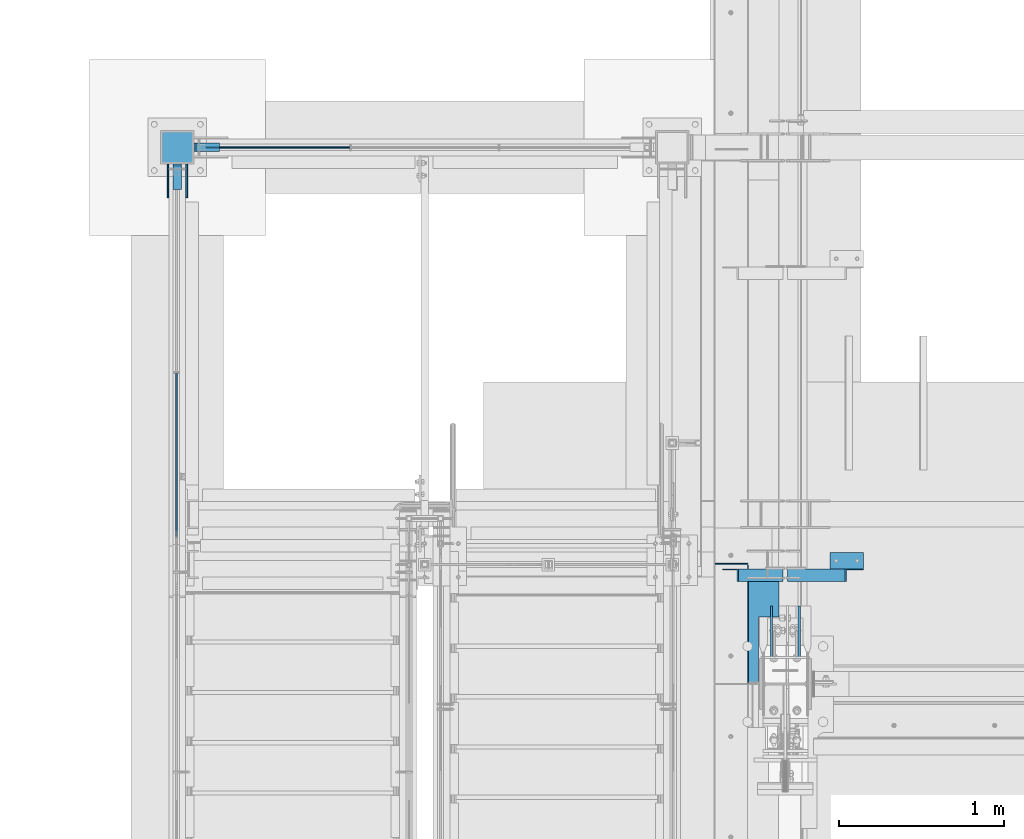
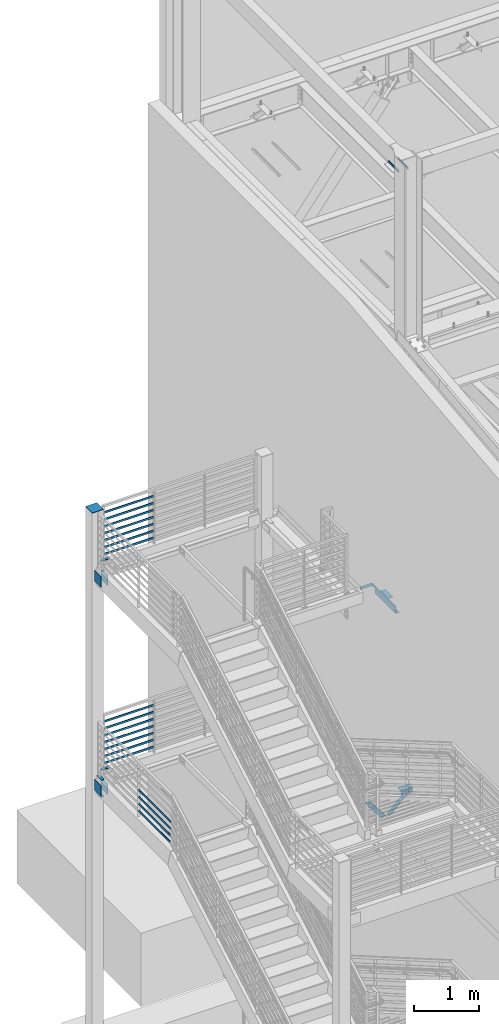
# One storey, part 876 of 1179: 32 beams, 2 members, 12 elements without a shape of their own.
"""IFC2X3 building model written with IfcOpenShell, lengths in millimetres."""

from ifc_helpers import new_model, si_unit, frame, origin_with_axes, place, context, subcontext, project, spatial, faceted_brep, material, type_object, element, aggregate, save


model = new_model("IFC2X3")

# Units and contexts
model_context = context("Model", 3, precision=1e-05, world=origin_with_axes())
body_context = subcontext(model_context, "Body", "Model", "MODEL_VIEW")
ifc_project = project(units=[si_unit("LENGTHUNIT", "METRE", prefix="MILLI"), si_unit("AREAUNIT", "SQUARE_METRE"), si_unit("VOLUMEUNIT", "CUBIC_METRE"), si_unit("MASSUNIT", "GRAM", prefix="KILO"), si_unit("TIMEUNIT", "SECOND"), si_unit("PLANEANGLEUNIT", "RADIAN"), si_unit("SOLIDANGLEUNIT", "STERADIAN"), si_unit("THERMODYNAMICTEMPERATUREUNIT", "DEGREE_CELSIUS"), si_unit("LUMINOUSINTENSITYUNIT", "LUMEN")], contexts=[model_context])

# Site, building, storey
site_placement = place(None, origin_with_axes())
site = spatial("IfcSite", under=ifc_project, at=site_placement, CompositionType="ELEMENT")
building_placement = place(site_placement, origin_with_axes())
building = spatial("IfcBuilding", under=site, at=building_placement, Name="Undefined", CompositionType="ELEMENT")
storey_placement = place(building_placement, origin_with_axes())
storey = spatial("IfcBuildingStorey", under=building, at=storey_placement, Name="Undefined", CompositionType="ELEMENT", Elevation=0.0)

# Assembly, beam
assembly_1_placement = place(storey_placement, origin_with_axes())
assembly_1 = element("IfcElementAssembly", 1, at=assembly_1_placement, inside=storey, Name="PLATE", AssemblyPlace="NOTDEFINED", PredefinedType="RIGID_FRAME")
ifc_material_1 = material(Name="STEEL/A572-GR.50")
beam_type_1 = type_object("IfcBeamType", PredefinedType="NOTDEFINED")
beam_1_placement = place(assembly_1_placement, frame((-2997.2, 37642.8, 8204.2), z_axis=(0.0, -1.0, 0.0), x_axis=(-1.0, 0.0, 0.0)))
beam_1 = element("IfcBeam", 2, at=beam_1_placement, type_object=beam_type_1, material=ifc_material_1, Name="PLATE", context=body_context, shape_type="Brep", body=[
    faceted_brep([(152.399999999998, 6.35000000000036, 25.4000000000015), (139.699999999998, -6.35000000000036, 25.4000000000015), (139.699999999998, -6.35000000000036, -25.4000000000015), (152.399999999998, 6.35000000000036, -25.4000000000015), (0.0, -6.35000000000036, -25.4000000000015), (0.0, -6.35000000000036, 25.4000000000015), (0.0, 6.35000000000036, 25.4000000000015), (0.0, 6.35000000000036, -25.4000000000015)], [[[0, 1, 2, 3]], [[4, 5, 6, 7]], [[7, 6, 0, 3]], [[4, 7, 3, 2]], [[5, 4, 2, 1]], [[6, 5, 1, 0]]]),
])
aggregate(assembly_1, [beam_1])

assembly_2_placement = place(storey_placement, origin_with_axes())
assembly_2 = element("IfcElementAssembly", 3, at=assembly_2_placement, inside=storey, Name="PLATE", AssemblyPlace="NOTDEFINED", PredefinedType="RIGID_FRAME")
beam_2_placement = place(assembly_2_placement, frame((-2997.2, 37642.8, 4292.6), z_axis=(0.0, -1.0, 0.0), x_axis=(-1.0, 0.0, 0.0)))
beam_2 = element("IfcBeam", 4, at=beam_2_placement, type_object=beam_type_1, material=ifc_material_1, Name="PLATE", context=body_context, shape_type="Brep", body=[
    faceted_brep([(152.399999999998, 6.35000000000036, 25.4000000000015), (139.699999999998, -6.35000000000036, 25.4000000000015), (139.699999999998, -6.35000000000036, -25.4000000000015), (152.399999999998, 6.35000000000036, -25.4000000000015), (0.0, -6.35000000000036, -25.4000000000015), (0.0, -6.35000000000036, 25.4000000000015), (0.0, 6.35000000000036, 25.4000000000015), (0.0, 6.35000000000036, -25.4000000000015)], [[[0, 1, 2, 3]], [[4, 5, 6, 7]], [[7, 6, 0, 3]], [[4, 7, 3, 2]], [[5, 4, 2, 1]], [[6, 5, 1, 0]]]),
])
aggregate(assembly_2, [beam_2])

assembly_3_placement = place(storey_placement, origin_with_axes())
assembly_3 = element("IfcElementAssembly", 5, at=assembly_3_placement, inside=storey, Name="COLUMN", AssemblyPlace="NOTDEFINED", PredefinedType="RIGID_FRAME")
beam_3_placement = place(assembly_3_placement, frame((-3251.2, 37388.8, 3975.10000002185), z_axis=(1.0, 0.0, 0.0), x_axis=(0.0, 1.0, 0.0)))
beam_3 = element("IfcBeam", 6, at=beam_3_placement, type_object=beam_type_1, material=ifc_material_1, Name="PLATE", context=body_context, shape_type="Brep", body=[
    faceted_brep([(152.399999999998, 6.35000000000036, 25.4000000000015), (139.699999999998, -6.35000000000036, 25.4000000000015), (139.699999999998, -6.35000000000036, -25.4000000000015), (152.399999999998, 6.35000000000036, -25.4000000000015), (0.0, -6.35000000000036, -25.4000000000015), (0.0, -6.35000000000036, 25.4000000000015), (0.0, 6.35000000000036, 25.4000000000015), (0.0, 6.35000000000036, -25.4000000000015)], [[[0, 1, 2, 3]], [[4, 5, 6, 7]], [[7, 6, 0, 3]], [[4, 7, 3, 2]], [[5, 4, 2, 1]], [[6, 5, 1, 0]]]),
])

assembly_4_placement = place(storey_placement, origin_with_axes())
assembly_4 = element("IfcElementAssembly", 7, at=assembly_4_placement, inside=storey, Name="PLATE", AssemblyPlace="NOTDEFINED", PredefinedType="RIGID_FRAME")
beam_4_placement = place(assembly_4_placement, frame((-3251.2, 37388.8, 4292.60000002185), z_axis=(1.0, 0.0, 0.0), x_axis=(0.0, 1.0, 0.0)))
beam_4 = element("IfcBeam", 8, at=beam_4_placement, type_object=beam_type_1, material=ifc_material_1, Name="PLATE", context=body_context, shape_type="Brep", body=[
    faceted_brep([(152.400000000001, -6.35000000000036, 25.4), (152.400000000001, -6.35000000000036, -25.4), (139.700000000004, 6.35000000000036, -25.4), (139.700000000004, 6.35000000000036, 25.4), (0.0, -6.35000000000036, -25.4000000000015), (0.0, -6.35000000000036, 25.4000000000015), (0.0, 6.35000000000036, 25.4000000000015), (0.0, 6.35000000000036, -25.4000000000015)], [[[0, 1, 2, 3]], [[4, 5, 6, 7]], [[6, 5, 0, 3]], [[7, 6, 3, 2]], [[4, 7, 2, 1]], [[5, 4, 1, 0]]]),
])
aggregate(assembly_4, [beam_4])

# Assembly, beams
assembly_5_placement = place(storey_placement, origin_with_axes())
assembly_5 = element("IfcElementAssembly", 9, at=assembly_5_placement, inside=storey, Name="GUARDRAIL", AssemblyPlace="NOTDEFINED", PredefinedType="RIGID_FRAME")
ifc_material_2 = material(Name="STEEL/A36")
beam_type_2 = type_object("IfcBeamType", PredefinedType="NOTDEFINED")
beam_5_placement = place(assembly_5_placement, frame((-3098.8000000022, 37642.8, 8305.85291815882), z_axis=(0.0, 0.0, 1.0), x_axis=(1.0, 0.0, 0.0)))
beam_5 = element("IfcBeam", 10, at=beam_5_placement, type_object=beam_type_2, material=ifc_material_2, Name="PLATE", context=body_context, shape_type="Brep", body=[
    faceted_brep([(19.0499992371956, 4.76249999999709, -19.0499999999993), (19.0499992371956, 4.76249999999709, 19.0499999999993), (892.704166666667, 4.76249999999709, 19.0499999999993), (892.704166666667, 4.76249999999709, -19.0499999999993), (19.0499992371956, -4.76249999999709, 19.0499999999993), (892.704166666667, -4.76249999999709, 19.0499999999993), (19.0499992371956, -4.76249999999709, -19.0499999999993), (892.704166666667, -4.76249999999709, -19.0499999999993)], [[[0, 1, 2, 3]], [[1, 4, 5, 2]], [[4, 6, 7, 5]], [[6, 0, 3, 7]], [[5, 7, 3, 2]], [[6, 4, 1, 0]]]),
])
beam_6_placement = place(assembly_5_placement, frame((-3098.8000000022, 37642.8, 8436.02791860674), z_axis=(0.0, 0.0, 1.0), x_axis=(1.0, 0.0, 0.0)))
beam_6 = element("IfcBeam", 11, at=beam_6_placement, type_object=beam_type_2, material=ifc_material_2, Name="PLATE", context=body_context, shape_type="Brep", body=[
    faceted_brep([(19.0499992371956, 4.76249999999709, -19.0499999999993), (19.0499992371956, 4.76249999999709, 19.0499999999993), (892.704166666667, 4.76249999999709, 19.0499999999993), (892.704166666667, 4.76249999999709, -19.0499999999993), (19.0499992371956, -4.76249999999709, 19.0499999999993), (892.704166666667, -4.76249999999709, 19.0499999999993), (19.0499992371956, -4.76249999999709, -19.0499999999993), (892.704166666667, -4.76249999999709, -19.0499999999993)], [[[0, 1, 2, 3]], [[1, 4, 5, 2]], [[4, 6, 7, 5]], [[6, 0, 3, 7]], [[5, 7, 3, 2]], [[6, 4, 1, 0]]]),
])
beam_7_placement = place(assembly_5_placement, frame((-3098.8000000022, 37642.8, 8566.20291816605), z_axis=(0.0, 0.0, 1.0), x_axis=(1.0, 0.0, 0.0)))
beam_7 = element("IfcBeam", 12, at=beam_7_placement, type_object=beam_type_2, material=ifc_material_2, Name="PLATE", context=body_context, shape_type="Brep", body=[
    faceted_brep([(19.0499992371956, 4.76249999999709, -19.0499999999993), (19.0499992371956, 4.76249999999709, 19.0499999999993), (892.704166666667, 4.76249999999709, 19.0499999999993), (892.704166666667, 4.76249999999709, -19.0499999999993), (19.0499992371956, -4.76249999999709, 19.0499999999993), (892.704166666667, -4.76249999999709, 19.0499999999993), (19.0499992371956, -4.76249999999709, -19.0499999999993), (892.704166666667, -4.76249999999709, -19.0499999999993)], [[[0, 1, 2, 3]], [[1, 4, 5, 2]], [[4, 6, 7, 5]], [[6, 0, 3, 7]], [[5, 7, 3, 2]], [[6, 4, 1, 0]]]),
])
beam_8_placement = place(assembly_5_placement, frame((-3098.8000000022, 37642.8, 8696.37791917919), z_axis=(0.0, 0.0, 1.0), x_axis=(1.0, 0.0, 0.0)))
beam_8 = element("IfcBeam", 13, at=beam_8_placement, type_object=beam_type_2, material=ifc_material_2, Name="PLATE", context=body_context, shape_type="Brep", body=[
    faceted_brep([(19.0499992371956, 4.76249999999709, -19.0499999999993), (19.0499992371956, 4.76249999999709, 19.0499999999993), (892.704166666667, 4.76249999999709, 19.0499999999993), (892.704166666667, 4.76249999999709, -19.0499999999993), (19.0499992371956, -4.76249999999709, 19.0499999999993), (892.704166666667, -4.76249999999709, 19.0499999999993), (19.0499992371956, -4.76249999999709, -19.0499999999993), (892.704166666667, -4.76249999999709, -19.0499999999993)], [[[0, 1, 2, 3]], [[1, 4, 5, 2]], [[4, 6, 7, 5]], [[6, 0, 3, 7]], [[5, 7, 3, 2]], [[6, 4, 1, 0]]]),
])
beam_9_placement = place(assembly_5_placement, frame((-3098.8000000022, 37642.8, 8826.55291917746), z_axis=(0.0, 0.0, 1.0), x_axis=(1.0, 0.0, 0.0)))
beam_9 = element("IfcBeam", 14, at=beam_9_placement, type_object=beam_type_2, material=ifc_material_2, Name="PLATE", context=body_context, shape_type="Brep", body=[
    faceted_brep([(19.0499992371956, 4.76249999999709, -19.0499999999993), (19.0499992371956, 4.76249999999709, 19.0499999999993), (892.704166666667, 4.76249999999709, 19.0499999999993), (892.704166666667, 4.76249999999709, -19.0499999999993), (19.0499992371956, -4.76249999999709, 19.0499999999993), (892.704166666667, -4.76249999999709, 19.0499999999993), (19.0499992371956, -4.76249999999709, -19.0499999999993), (892.704166666667, -4.76249999999709, -19.0499999999993)], [[[0, 1, 2, 3]], [[1, 4, 5, 2]], [[4, 6, 7, 5]], [[6, 0, 3, 7]], [[5, 7, 3, 2]], [[6, 4, 1, 0]]]),
])
beam_10_placement = place(assembly_5_placement, frame((-3098.8000000022, 37642.8, 8956.72791918095), z_axis=(0.0, 0.0, 1.0), x_axis=(1.0, 0.0, 0.0)))
beam_10 = element("IfcBeam", 15, at=beam_10_placement, type_object=beam_type_2, material=ifc_material_2, Name="PLATE", context=body_context, shape_type="Brep", body=[
    faceted_brep([(19.0499992371956, 4.76249999999709, -19.0499999999993), (19.0499992371956, 4.76249999999709, 19.0499999999993), (892.704166666667, 4.76249999999709, 19.0499999999993), (892.704166666667, 4.76249999999709, -19.0499999999993), (19.0499992371956, -4.76249999999709, 19.0499999999993), (892.704166666667, -4.76249999999709, 19.0499999999993), (19.0499992371956, -4.76249999999709, -19.0499999999993), (892.704166666667, -4.76249999999709, -19.0499999999993)], [[[0, 1, 2, 3]], [[1, 4, 5, 2]], [[4, 6, 7, 5]], [[6, 0, 3, 7]], [[5, 7, 3, 2]], [[6, 4, 1, 0]]]),
])
beam_11_placement = place(assembly_5_placement, frame((-3098.8000000022, 37642.8, 9086.90291918618), z_axis=(0.0, 0.0, 1.0), x_axis=(1.0, 0.0, 0.0)))
beam_11 = element("IfcBeam", 16, at=beam_11_placement, type_object=beam_type_2, material=ifc_material_2, Name="PLATE", context=body_context, shape_type="Brep", body=[
    faceted_brep([(19.0499992371956, 4.76249999999709, -19.0499999999993), (19.0499992371956, 4.76249999999709, 19.0499999999993), (892.704166666667, 4.76249999999709, 19.0499999999993), (892.704166666667, 4.76249999999709, -19.0499999999993), (19.0499992371956, -4.76249999999709, 19.0499999999993), (892.704166666667, -4.76249999999709, 19.0499999999993), (19.0499992371956, -4.76249999999709, -19.0499999999993), (892.704166666667, -4.76249999999709, -19.0499999999993)], [[[0, 1, 2, 3]], [[1, 4, 5, 2]], [[4, 6, 7, 5]], [[6, 0, 3, 7]], [[5, 7, 3, 2]], [[6, 4, 1, 0]]]),
])
aggregate(assembly_5, [beam_5, beam_6, beam_7, beam_8, beam_9, beam_10, beam_11])

assembly_6_placement = place(storey_placement, origin_with_axes())
assembly_6 = element("IfcElementAssembly", 17, at=assembly_6_placement, inside=storey, Name="GUARDRAIL", AssemblyPlace="NOTDEFINED", PredefinedType="RIGID_FRAME")
beam_12_placement = place(assembly_6_placement, frame((-3098.8000000022, 37642.8, 4394.2529178486), z_axis=(0.0, 0.0, 1.0), x_axis=(1.0, 0.0, 0.0)))
beam_12 = element("IfcBeam", 18, at=beam_12_placement, type_object=beam_type_2, material=ifc_material_2, Name="PLATE", context=body_context, shape_type="Brep", body=[
    faceted_brep([(19.0499992371956, 4.76249999999709, -19.0499999999993), (19.0499992371956, 4.76249999999709, 19.0499999999993), (892.704166666667, 4.76249999999709, 19.0499999999993), (892.704166666667, 4.76249999999709, -19.0499999999993), (19.0499992371956, -4.76249999999709, 19.0499999999993), (892.704166666667, -4.76249999999709, 19.0499999999993), (19.0499992371956, -4.76249999999709, -19.0499999999993), (892.704166666667, -4.76249999999709, -19.0499999999993)], [[[0, 1, 2, 3]], [[1, 4, 5, 2]], [[4, 6, 7, 5]], [[6, 0, 3, 7]], [[5, 7, 3, 2]], [[6, 4, 1, 0]]]),
])
beam_13_placement = place(assembly_6_placement, frame((-3098.8000000022, 37642.8, 4524.42791829651), z_axis=(0.0, 0.0, 1.0), x_axis=(1.0, 0.0, 0.0)))
beam_13 = element("IfcBeam", 19, at=beam_13_placement, type_object=beam_type_2, material=ifc_material_2, Name="PLATE", context=body_context, shape_type="Brep", body=[
    faceted_brep([(19.0499992371956, 4.76249999999709, -19.0499999999993), (19.0499992371956, 4.76249999999709, 19.0499999999993), (892.704166666667, 4.76249999999709, 19.0499999999993), (892.704166666667, 4.76249999999709, -19.0499999999993), (19.0499992371956, -4.76249999999709, 19.0499999999993), (892.704166666667, -4.76249999999709, 19.0499999999993), (19.0499992371956, -4.76249999999709, -19.0499999999993), (892.704166666667, -4.76249999999709, -19.0499999999993)], [[[0, 1, 2, 3]], [[1, 4, 5, 2]], [[4, 6, 7, 5]], [[6, 0, 3, 7]], [[5, 7, 3, 2]], [[6, 4, 1, 0]]]),
])
beam_14_placement = place(assembly_6_placement, frame((-3098.8000000022, 37642.8, 4654.60291785583), z_axis=(0.0, 0.0, 1.0), x_axis=(1.0, 0.0, 0.0)))
beam_14 = element("IfcBeam", 20, at=beam_14_placement, type_object=beam_type_2, material=ifc_material_2, Name="PLATE", context=body_context, shape_type="Brep", body=[
    faceted_brep([(19.0499992371956, 4.76249999999709, -19.0499999999993), (19.0499992371956, 4.76249999999709, 19.0499999999993), (892.704166666667, 4.76249999999709, 19.0499999999993), (892.704166666667, 4.76249999999709, -19.0499999999993), (19.0499992371956, -4.76249999999709, 19.0499999999993), (892.704166666667, -4.76249999999709, 19.0499999999993), (19.0499992371956, -4.76249999999709, -19.0499999999993), (892.704166666667, -4.76249999999709, -19.0499999999993)], [[[0, 1, 2, 3]], [[1, 4, 5, 2]], [[4, 6, 7, 5]], [[6, 0, 3, 7]], [[5, 7, 3, 2]], [[6, 4, 1, 0]]]),
])
beam_15_placement = place(assembly_6_placement, frame((-3098.8000000022, 37642.8, 4784.77791886897), z_axis=(0.0, 0.0, 1.0), x_axis=(1.0, 0.0, 0.0)))
beam_15 = element("IfcBeam", 21, at=beam_15_placement, type_object=beam_type_2, material=ifc_material_2, Name="PLATE", context=body_context, shape_type="Brep", body=[
    faceted_brep([(19.0499992371956, 4.76249999999709, -19.0499999999993), (19.0499992371956, 4.76249999999709, 19.0499999999993), (892.704166666667, 4.76249999999709, 19.0499999999993), (892.704166666667, 4.76249999999709, -19.0499999999993), (19.0499992371956, -4.76249999999709, 19.0499999999993), (892.704166666667, -4.76249999999709, 19.0499999999993), (19.0499992371956, -4.76249999999709, -19.0499999999993), (892.704166666667, -4.76249999999709, -19.0499999999993)], [[[0, 1, 2, 3]], [[1, 4, 5, 2]], [[4, 6, 7, 5]], [[6, 0, 3, 7]], [[5, 7, 3, 2]], [[6, 4, 1, 0]]]),
])
beam_16_placement = place(assembly_6_placement, frame((-3098.8000000022, 37642.8, 4914.95291886724), z_axis=(0.0, 0.0, 1.0), x_axis=(1.0, 0.0, 0.0)))
beam_16 = element("IfcBeam", 22, at=beam_16_placement, type_object=beam_type_2, material=ifc_material_2, Name="PLATE", context=body_context, shape_type="Brep", body=[
    faceted_brep([(19.0499992371956, 4.76249999999709, -19.0499999999993), (19.0499992371956, 4.76249999999709, 19.0499999999993), (892.704166666667, 4.76249999999709, 19.0499999999993), (892.704166666667, 4.76249999999709, -19.0499999999993), (19.0499992371956, -4.76249999999709, 19.0499999999993), (892.704166666667, -4.76249999999709, 19.0499999999993), (19.0499992371956, -4.76249999999709, -19.0499999999993), (892.704166666667, -4.76249999999709, -19.0499999999993)], [[[0, 1, 2, 3]], [[1, 4, 5, 2]], [[4, 6, 7, 5]], [[6, 0, 3, 7]], [[5, 7, 3, 2]], [[6, 4, 1, 0]]]),
])
beam_17_placement = place(assembly_6_placement, frame((-3098.8000000022, 37642.8, 5045.12791887072), z_axis=(0.0, 0.0, 1.0), x_axis=(1.0, 0.0, 0.0)))
beam_17 = element("IfcBeam", 23, at=beam_17_placement, type_object=beam_type_2, material=ifc_material_2, Name="PLATE", context=body_context, shape_type="Brep", body=[
    faceted_brep([(19.0499992371956, 4.76249999999709, -19.0499999999993), (19.0499992371956, 4.76249999999709, 19.0499999999993), (892.704166666667, 4.76249999999709, 19.0499999999993), (892.704166666667, 4.76249999999709, -19.0499999999993), (19.0499992371956, -4.76249999999709, 19.0499999999993), (892.704166666667, -4.76249999999709, 19.0499999999993), (19.0499992371956, -4.76249999999709, -19.0499999999993), (892.704166666667, -4.76249999999709, -19.0499999999993)], [[[0, 1, 2, 3]], [[1, 4, 5, 2]], [[4, 6, 7, 5]], [[6, 0, 3, 7]], [[5, 7, 3, 2]], [[6, 4, 1, 0]]]),
])
beam_18_placement = place(assembly_6_placement, frame((-3098.8000000022, 37642.8, 5175.30291887596), z_axis=(0.0, 0.0, 1.0), x_axis=(1.0, 0.0, 0.0)))
beam_18 = element("IfcBeam", 24, at=beam_18_placement, type_object=beam_type_2, material=ifc_material_2, Name="PLATE", context=body_context, shape_type="Brep", body=[
    faceted_brep([(19.0499992371956, 4.76249999999709, -19.0499999999993), (19.0499992371956, 4.76249999999709, 19.0499999999993), (892.704166666667, 4.76249999999709, 19.0499999999993), (892.704166666667, 4.76249999999709, -19.0499999999993), (19.0499992371956, -4.76249999999709, 19.0499999999993), (892.704166666667, -4.76249999999709, 19.0499999999993), (19.0499992371956, -4.76249999999709, -19.0499999999993), (892.704166666667, -4.76249999999709, -19.0499999999993)], [[[0, 1, 2, 3]], [[1, 4, 5, 2]], [[4, 6, 7, 5]], [[6, 0, 3, 7]], [[5, 7, 3, 2]], [[6, 4, 1, 0]]]),
])
aggregate(assembly_6, [beam_12, beam_13, beam_14, beam_15, beam_16, beam_17, beam_18])

assembly_7_placement = place(storey_placement, origin_with_axes())
assembly_7 = element("IfcElementAssembly", 25, at=assembly_7_placement, inside=storey, Name="GUARDRAIL", AssemblyPlace="NOTDEFINED", PredefinedType="RIGID_FRAME")
beam_19_placement = place(assembly_7_placement, frame((-3257.54999923555, 36279.6666666667, 4394.23611822362), z_axis=(0.0, 0.0, 1.0), x_axis=(0.0, -1.0, 0.0)))
beam_19 = element("IfcBeam", 26, at=beam_19_placement, type_object=beam_type_2, material=ifc_material_2, Name="PLATE", context=body_context, shape_type="Brep", body=[
    faceted_brep([(4.76250000197615, 4.76249999999999, -19.0500000000002), (4.76250000197615, 4.76249999999999, 19.0500000000002), (970.583241761939, 4.76249999999982, 19.0500000000002), (960.349234820969, 4.76249999999982, -19.0500000000002), (4.76250000197615, -4.76249999999999, 19.0500000000002), (970.583241761939, -4.76249999999982, 19.0500000000002), (4.76250000197615, -4.76249999999999, -19.0500000000002), (960.349234820969, -4.76249999999982, -19.0500000000002)], [[[0, 1, 2, 3]], [[1, 4, 5, 2]], [[4, 6, 7, 5]], [[6, 0, 3, 7]], [[5, 7, 3, 2]], [[6, 4, 1, 0]]]),
])
beam_20_placement = place(assembly_7_placement, frame((-3257.54999923555, 36279.6666666664, 4524.41111822362), z_axis=(0.0, 0.0, 1.0), x_axis=(0.0, -1.0, 0.0)))
beam_20 = element("IfcBeam", 27, at=beam_20_placement, type_object=beam_type_2, material=ifc_material_2, Name="PLATE", context=body_context, shape_type="Brep", body=[
    faceted_brep([(4.76250000197615, 4.76249999999999, -19.0500000000002), (4.76250000197615, 4.76249999999999, 19.0500000000002), (980.817248729763, 4.76249999999982, 19.0500000000002), (970.583241788787, 4.76249999999982, -19.0500000000002), (4.76250000197615, -4.76249999999999, 19.0500000000002), (980.817248729763, -4.76249999999982, 19.0500000000002), (4.76250000197615, -4.76249999999999, -19.0500000000002), (970.583241788787, -4.76249999999982, -19.0500000000002)], [[[0, 1, 2, 3]], [[1, 4, 5, 2]], [[4, 6, 7, 5]], [[6, 0, 3, 7]], [[5, 7, 3, 2]], [[6, 4, 1, 0]]]),
])
beam_21_placement = place(assembly_7_placement, frame((-3257.54999923555, 36279.6666666664, 4654.58611822362), z_axis=(0.0, 0.0, 1.0), x_axis=(0.0, -1.0, 0.0)))
beam_21 = element("IfcBeam", 28, at=beam_21_placement, type_object=beam_type_2, material=ifc_material_2, Name="PLATE", context=body_context, shape_type="Brep", body=[
    faceted_brep([(4.76250000197615, 4.76249999999999, -19.0500000000002), (4.76250000197615, 4.76249999999999, 19.0500000000002), (991.051255704697, 4.76249999999982, 19.0500000000002), (980.817248763728, 4.76249999999982, -19.0500000000002), (4.76250000197615, -4.76249999999999, 19.0500000000002), (991.051255704697, -4.76249999999982, 19.0500000000002), (4.76250000197615, -4.76249999999999, -19.0500000000002), (980.817248763728, -4.76249999999982, -19.0500000000002)], [[[0, 1, 2, 3]], [[1, 4, 5, 2]], [[4, 6, 7, 5]], [[6, 0, 3, 7]], [[5, 7, 3, 2]], [[6, 4, 1, 0]]]),
])
beam_22_placement = place(assembly_7_placement, frame((-3257.54999923555, 36279.6666666667, 4784.76111822362), z_axis=(0.0, 0.0, 1.0), x_axis=(0.0, -1.0, 0.0)))
beam_22 = element("IfcBeam", 29, at=beam_22_placement, type_object=beam_type_2, material=ifc_material_2, Name="PLATE", context=body_context, shape_type="Brep", body=[
    faceted_brep([(4.76250000197615, 4.76249999999999, -19.0500000000002), (4.76250000197615, 4.76249999999999, 19.0500000000002), (1001.28526267422, 4.76249999999982, 19.0500000000002), (991.05125573324, 4.76249999999982, -19.0500000000002), (4.76250000197615, -4.76249999999999, 19.0500000000002), (1001.28526267422, -4.76249999999982, 19.0500000000002), (4.76250000197615, -4.76249999999999, -19.0500000000002), (991.05125573324, -4.76249999999982, -19.0500000000002)], [[[0, 1, 2, 3]], [[1, 4, 5, 2]], [[4, 6, 7, 5]], [[6, 0, 3, 7]], [[5, 7, 3, 2]], [[6, 4, 1, 0]]]),
])
aggregate(assembly_7, [beam_19, beam_20, beam_21, beam_22])

# Assembly, member
assembly_8_placement = place(storey_placement, origin_with_axes())
assembly_8 = element("IfcElementAssembly", 30, at=assembly_8_placement, inside=storey, Name="ANGLE", AssemblyPlace="NOTDEFINED", PredefinedType="RIGID_FRAME")
member_type = type_object("IfcMemberType", Name="L3X3X1/4", PredefinedType="NOTDEFINED")
member_1_placement = place(assembly_8_placement, frame((472.414639168561, 35050.4125, 3736.19330123132), z_axis=(0.0, -1.0, 0.0), x_axis=(0.729484494811633, 0.0, 0.683997347823379)))
member_1 = element("IfcMember", 31, at=member_1_placement, type_object=member_type, material=ifc_material_2, Name="ANGLE", ObjectType="L3X3X1/4", context=body_context, shape_type="Brep", body=[
    faceted_brep([(0.0, 38.0999999999985, -38.0999999999999), (0.0, 38.0999999999985, 38.0999999999999), (475.752341075195, 38.0999999999181, 38.1000000000004), (475.752341075195, 38.0999999999181, -38.1000000000004), (0.0, 31.75, 38.1000000000004), (482.524628360803, 31.7499999999177, 38.1000000000004), (0.0, 31.75, -31.75), (482.524628360803, 31.7499999999177, -31.75), (0.0, -38.0999999999985, -31.75), (557.019788502486, -38.1000000000854, -31.75), (0.0, -38.0999999999985, -38.0999999999999), (557.019788502486, -38.1000000000854, -38.1000000000004)], [[[0, 1, 2, 3]], [[1, 4, 5, 2]], [[4, 6, 7, 5]], [[6, 8, 9, 7]], [[8, 10, 11, 9]], [[10, 0, 3, 11]], [[5, 7, 9, 11, 3, 2]], [[10, 8, 6, 4, 1, 0]]]),
])
aggregate(assembly_8, [member_1])

assembly_9_placement = place(storey_placement, origin_with_axes())
assembly_9 = element("IfcElementAssembly", 32, at=assembly_9_placement, inside=storey, Name="ANGLE", AssemblyPlace="NOTDEFINED", PredefinedType="RIGID_FRAME")
member_2_placement = place(assembly_9_placement, frame((80.8196258456446, 35050.4125, 4125.56128839178), z_axis=(0.0, -1.0, 0.0), x_axis=(0.614083067285056, 0.0, -0.789241399366364)))
member_2 = element("IfcMember", 33, at=member_2_placement, type_object=member_type, material=ifc_material_2, Name="ANGLE", ObjectType="L3X3X1/4", context=body_context, shape_type="Brep", body=[
    faceted_brep([(59.3707492954454, 38.0999999999781, -38.1000000000004), (59.3707492954454, 38.0999999999781, 38.1000000000004), (499.083854779058, 38.0999999998585, 38.1000000000004), (499.083854779058, 38.0999999998585, -38.1000000000004), (54.4300207928691, 31.7499999999804, 38.1000000000004), (499.083854779056, 31.7499999998595, 38.1000000000004), (54.4300207928691, 31.7499999999804, -31.75), (499.083854779056, 31.7499999998595, -31.75), (0.0820072645328764, -38.0999999999945, -31.75), (499.083854779043, -38.10000000013, -31.75), (0.0820072645328764, -38.0999999999945, -38.1000000000004), (499.083854779043, -38.10000000013, -38.1000000000004)], [[[0, 1, 2, 3]], [[1, 4, 5, 2]], [[4, 6, 7, 5]], [[6, 8, 9, 7]], [[8, 10, 11, 9]], [[10, 0, 3, 11]], [[5, 7, 9, 11, 3, 2]], [[10, 8, 6, 4, 1, 0]]]),
])
aggregate(assembly_9, [member_2])

# Assembly, beam
assembly_10_placement = place(storey_placement, origin_with_axes())
assembly_10 = element("IfcElementAssembly", 34, at=assembly_10_placement, inside=storey, Name="ANGLE", AssemblyPlace="NOTDEFINED", PredefinedType="RIGID_FRAME")
beam_type_3 = type_object("IfcBeamType", Name="L4X4X1/4", PredefinedType="NOTDEFINED")
beam_23_placement = place(assembly_10_placement, frame((701.59635534156, 35139.3125, 4051.3), z_axis=(0.0, 0.0, -1.0), x_axis=(1.0, 0.0, 0.0)))
beam_23 = element("IfcBeam", 35, at=beam_23_placement, type_object=beam_type_3, material=ifc_material_2, Name="ANGLE", ObjectType="L4X4X1/4", context=body_context, shape_type="Brep", body=[
    faceted_brep([(1.90993887372315e-11, 50.8000000000002, -50.8000000000002), (1.90993887372315e-11, 50.8000000000002, 50.8000000000002), (203.200000000001, 50.7999999999993, 50.8000000000002), (203.200000000001, 50.7999999999993, -50.8000000000002), (0.0, 44.4500000000007, 50.8000000000002), (203.200000000001, 44.4500000000007, 50.8000000000002), (0.0, 44.4500000000007, -44.4499999999998), (203.200000000001, 44.4500000000007, -44.4499999999998), (0.0, -50.7999999999993, -44.4499999999998), (203.200000000001, -50.7999999999993, -44.4499999999998), (-1.81898940354586e-11, -50.7999999999997, -50.8000000000002), (203.200000000001, -50.7999999999993, -50.8000000000002)], [[[0, 1, 2, 3]], [[1, 4, 5, 2]], [[4, 6, 7, 5]], [[6, 8, 9, 7]], [[8, 10, 11, 9]], [[10, 0, 3, 11]], [[5, 7, 9, 11, 3, 2]], [[10, 8, 6, 4, 1, 0]]]),
])
aggregate(assembly_10, [beam_23])

# Beam
beam_type_4 = type_object("IfcBeamType", PredefinedType="NOTDEFINED")
beam_24_placement = place(assembly_3_placement, frame((-3251.2, 37541.2, 9228.1375), z_axis=(1.0, 0.0, 0.0), x_axis=(0.0, 1.0, 0.0)))
beam_24 = element("IfcBeam", 36, at=beam_24_placement, type_object=beam_type_4, material=ifc_material_2, Name="PLATE", context=body_context, shape_type="Brep", body=[
    faceted_brep([(0.0, 4.76250000000073, -101.6), (0.0, 4.76250000000073, 101.6), (203.199999999997, 4.76250000000073, 101.6), (203.199999999997, 4.76250000000073, -101.6), (0.0, -4.76250000000073, 101.6), (203.199999999997, -4.76250000000073, 101.6), (0.0, -4.76250000000073, -101.6), (203.199999999997, -4.76250000000073, -101.6)], [[[0, 1, 2, 3]], [[1, 4, 5, 2]], [[4, 6, 7, 5]], [[6, 0, 3, 7]], [[5, 7, 3, 2]], [[6, 4, 1, 0]]]),
])

beam_25_placement = place(assembly_3_placement, frame((-3308.35000001418, 37338.0000009103, 4133.79708182452), z_axis=(0.0, 0.0, 1.0), x_axis=(0.0, 1.0, 0.0)))
beam_25 = element("IfcBeam", 37, at=beam_25_placement, type_object=beam_type_4, material=ifc_material_2, Name="PLATE", context=body_context, shape_type="Brep", body=[
    faceted_brep([(0.0, 4.76250000000073, -101.6), (0.0, 4.76250000000073, 101.6), (203.199999999997, 4.76250000000073, 101.6), (203.199999999997, 4.76250000000073, -101.6), (0.0, -4.76250000000073, 101.6), (203.199999999997, -4.76250000000073, 101.6), (0.0, -4.76250000000073, -101.6), (203.199999999997, -4.76250000000073, -101.6)], [[[0, 1, 2, 3]], [[1, 4, 5, 2]], [[4, 6, 7, 5]], [[6, 0, 3, 7]], [[5, 7, 3, 2]], [[6, 4, 1, 0]]]),
])

beam_26_placement = place(assembly_3_placement, frame((-3194.05, 37338.0, 4133.85000002185), z_axis=(0.0, 0.0, 1.0), x_axis=(0.0, 1.0, 0.0)))
beam_26 = element("IfcBeam", 38, at=beam_26_placement, type_object=beam_type_4, material=ifc_material_2, Name="PLATE", context=body_context, shape_type="Brep", body=[
    faceted_brep([(0.0, 4.76250000000073, -101.6), (0.0, 4.76250000000073, 101.6), (203.199999999997, 4.76250000000073, 101.6), (203.199999999997, 4.76250000000073, -101.6), (0.0, -4.76250000000073, 101.6), (203.199999999997, -4.76250000000073, 101.6), (0.0, -4.76250000000073, -101.6), (203.199999999997, -4.76250000000073, -101.6)], [[[0, 1, 2, 3]], [[1, 4, 5, 2]], [[4, 6, 7, 5]], [[6, 0, 3, 7]], [[5, 7, 3, 2]], [[6, 4, 1, 0]]]),
])

beam_27_placement = place(assembly_3_placement, frame((-3194.05, 37338.0, 8045.44999894209), z_axis=(0.0, 0.0, 1.0), x_axis=(0.0, 1.0, 0.0)))
beam_27 = element("IfcBeam", 39, at=beam_27_placement, type_object=beam_type_4, material=ifc_material_2, Name="PLATE", context=body_context, shape_type="Brep", body=[
    faceted_brep([(0.0, 4.76250000000073, -101.6), (0.0, 4.76250000000073, 101.6), (203.199999999997, 4.76250000000073, 101.6), (203.199999999997, 4.76250000000073, -101.6), (0.0, -4.76250000000073, 101.6), (203.199999999997, -4.76250000000073, 101.6), (0.0, -4.76250000000073, -101.6), (203.199999999997, -4.76250000000073, -101.6)], [[[0, 1, 2, 3]], [[1, 4, 5, 2]], [[4, 6, 7, 5]], [[6, 0, 3, 7]], [[5, 7, 3, 2]], [[6, 4, 1, 0]]]),
])

beam_28_placement = place(assembly_3_placement, frame((-3308.35, 37338.0, 8045.44999894209), z_axis=(0.0, 0.0, 1.0), x_axis=(0.0, 1.0, 0.0)))
beam_28 = element("IfcBeam", 40, at=beam_28_placement, type_object=beam_type_4, material=ifc_material_2, Name="PLATE", context=body_context, shape_type="Brep", body=[
    faceted_brep([(0.0, 4.76250000000073, -101.6), (0.0, 4.76250000000073, 101.6), (203.199999999997, 4.76250000000073, 101.6), (203.199999999997, 4.76250000000073, -101.6), (0.0, -4.76250000000073, 101.6), (203.199999999997, -4.76250000000073, 101.6), (0.0, -4.76250000000073, -101.6), (203.199999999997, -4.76250000000073, -101.6)], [[[0, 1, 2, 3]], [[1, 4, 5, 2]], [[4, 6, 7, 5]], [[6, 0, 3, 7]], [[5, 7, 3, 2]], [[6, 4, 1, 0]]]),
])

aggregate(assembly_3, [beam_24, beam_25, beam_26, beam_27, beam_28, beam_3])

# Assembly, beams
assembly_11_placement = place(storey_placement, origin_with_axes())
assembly_11 = element("IfcElementAssembly", 41, at=assembly_11_placement, inside=storey, Name="BEAM", AssemblyPlace="NOTDEFINED", PredefinedType="RIGID_FRAME")
beam_type_5 = type_object("IfcBeamType", PredefinedType="NOTDEFINED")
beam_29_placement = place(assembly_11_placement, frame((392.112494483499, 34753.549999668, 8016.875), z_axis=(0.0, 1.0, 0.0), x_axis=(-1.0, 0.0, 0.0)))
beam_29 = element("IfcBeam", 42, at=beam_29_placement, type_object=beam_type_5, material=ifc_material_2, Name="BENT_PLATE", context=body_context, shape_type="Brep", body=[
    faceted_brep([(188.912479178456, -3.17500005802776, 279.456482420195), (188.912476638623, 76.2000127121655, 279.456478446591), (182.562476638623, 76.2000125597633, 279.456478446584), (182.562478975263, 3.17499994392347, 279.456482102658), (8.63224158820231e-10, 3.17500000000109, 279.456482102651), (-1.08951780930511e-09, -3.17499999999927, 279.456482419853), (188.912476638586, 76.2000066886458, 358.774995625208), (182.562476638582, 76.2000065362436, 358.775000000292), (7.6397554948926e-11, -3.17500000000291, 44.4500007629631), (7.6397554948926e-11, 3.17500000000291, 44.4500007629631), (123.824994552903, 3.17499996196511, 44.4500022236534), (123.824994756101, -3.17500003803434, 44.4500022236534), (123.824993511892, 3.17499996196511, -358.774999999841), (123.82499371509, -3.17500003803434, -358.774999999841), (182.562478975913, 3.17499994392347, -358.774999999754), (182.562474911837, 130.175011981305, -358.774999999674), (188.912474911837, 130.1750121845, -358.774999999674), (188.912479179107, -3.17500005802776, -358.774999999754), (188.912474911529, 130.175012184051, 358.775000000329), (182.562474911529, 130.175011980857, 358.775000000322)], [[[0, 1, 2, 3, 4, 5]], [[6, 7, 2, 1]], [[8, 9, 10, 11]], [[11, 10, 12, 13]], [[14, 15, 16, 17, 13, 12]], [[18, 16, 15, 19]], [[0, 17, 16, 18, 6, 1]], [[8, 11, 13, 17, 0, 5]], [[9, 8, 5, 4]], [[14, 12, 10, 9, 4, 3]], [[19, 15, 14, 3, 2, 7]], [[18, 19, 7, 6]]]),
])
beam_type_6 = type_object("IfcBeamType", PredefinedType="NOTDEFINED")
beam_30_placement = place(assembly_11_placement, frame((6.34999887861329, 35121.8500000581, 8120.0624999986), z_axis=(0.0, 0.0, 1.0), x_axis=(1.0, 0.0, 0.0)))
beam_30 = element("IfcBeam", 43, at=beam_30_placement, type_object=beam_type_6, material=ifc_material_2, Name="PLATE", context=body_context, shape_type="Brep", body=[
    faceted_brep([(8.88178419700125e-16, 3.17500000000291, -26.9875000000002), (8.88178419700125e-16, 3.17500000000291, 26.9875000000002), (196.850017626809, 3.17500000062864, 26.9875000000002), (196.850017626809, 3.17500000062864, -26.9875000000002), (-1.77635683940025e-15, -3.17500000000291, 26.9875000000002), (196.850017626809, -3.1749999993699, 26.9875000000002), (-1.77635683940025e-15, -3.17500000000291, -26.9875000000002), (196.850017626809, -3.1749999993699, -26.9875000000002)], [[[0, 1, 2, 3]], [[1, 4, 5, 2]], [[4, 6, 7, 5]], [[6, 0, 3, 7]], [[5, 7, 3, 2]], [[6, 4, 1, 0]]]),
])
aggregate(assembly_11, [beam_30, beam_29])

assembly_12_placement = place(storey_placement, origin_with_axes())
assembly_12 = element("IfcElementAssembly", 44, at=assembly_12_placement, inside=storey, Name="COLUMN", AssemblyPlace="NOTDEFINED", PredefinedType="RIGID_FRAME")
beam_type_7 = type_object("IfcBeamType", PredefinedType="NOTDEFINED")
beam_31_placement = place(assembly_12_placement, frame((515.9375, 34863.0875000406, 16141.7), z_axis=(0.0, 0.0, 1.0), x_axis=(0.0, -1.0, 0.0)))
beam_31 = element("IfcBeam", 45, at=beam_31_placement, type_object=beam_type_7, material=ifc_material_2, Name="PLATE", context=body_context, shape_type="Brep", body=[
    faceted_brep([(0.0, 6.34999999999854, -19.0499999999993), (0.0, 6.35000000000036, 19.0499999999993), (317.5, 6.34999999999854, 19.0499999999993), (317.5, 6.34999999999854, -19.0499999999993), (0.0, -6.35000000000036, 19.0499999999993), (317.5, -6.34999999999854, 19.0499999999993), (0.0, -6.34999999999854, -19.0499999999993), (317.5, -6.34999999999854, -19.0499999999993)], [[[0, 1, 2, 3]], [[1, 4, 5, 2]], [[4, 6, 7, 5]], [[6, 0, 3, 7]], [[5, 7, 3, 2]], [[6, 4, 1, 0]]]),
])
beam_32_placement = place(assembly_12_placement, frame((347.6625, 34863.0875000406, 16141.7), z_axis=(0.0, 0.0, 1.0), x_axis=(0.0, -1.0, 0.0)))
beam_32 = element("IfcBeam", 46, at=beam_32_placement, type_object=beam_type_7, material=ifc_material_2, Name="PLATE", context=body_context, shape_type="Brep", body=[
    faceted_brep([(0.0, 6.34999999999854, -19.0499999999993), (0.0, 6.35000000000036, 19.0499999999993), (317.5, 6.34999999999854, 19.0499999999993), (317.5, 6.34999999999854, -19.0499999999993), (0.0, -6.35000000000036, 19.0499999999993), (317.5, -6.34999999999854, 19.0499999999993), (0.0, -6.34999999999854, -19.0499999999993), (317.5, -6.34999999999854, -19.0499999999993)], [[[0, 1, 2, 3]], [[1, 4, 5, 2]], [[4, 6, 7, 5]], [[6, 0, 3, 7]], [[5, 7, 3, 2]], [[6, 4, 1, 0]]]),
])
aggregate(assembly_12, [beam_31, beam_32])

save(model, "model.ifc")
